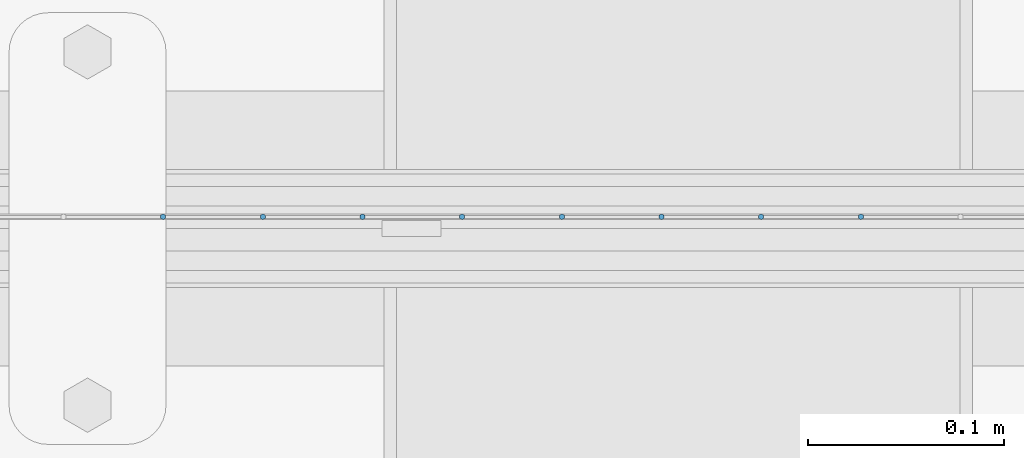
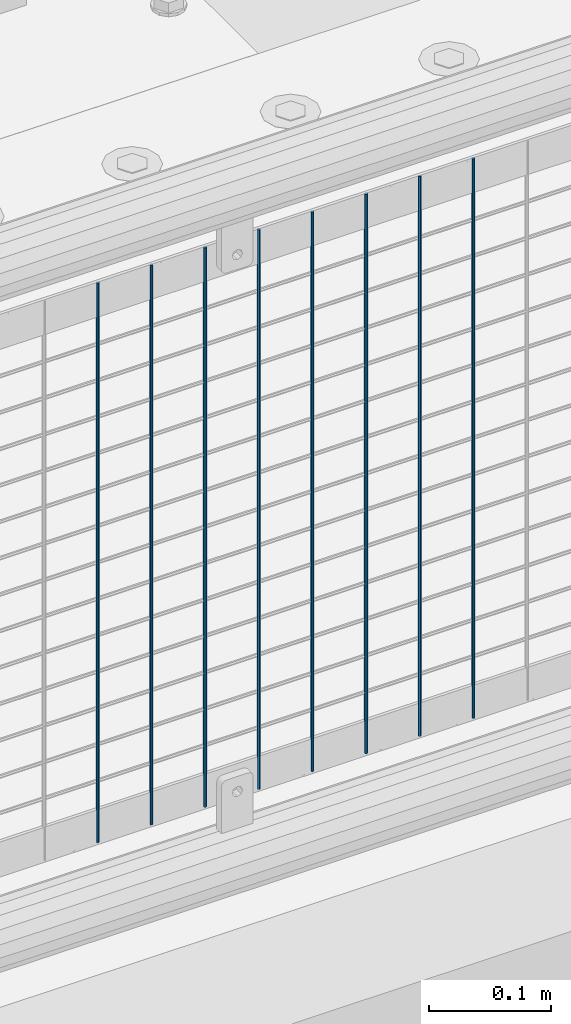
# One storey, part 100 of 242: 8 columns.
"""IFC2X3 building model written with IfcOpenShell, lengths in millimetres."""

from ifc_helpers import new_model, si_unit, frame, origin_with_axes, place, context, subcontext, project, spatial, faceted_brep, material, type_object, element, save


model = new_model("IFC2X3")

# Units and contexts
model_context = context("Model", 3, precision=1e-05, world=origin_with_axes())
body_context = subcontext(model_context, "Body", "Model", "MODEL_VIEW")
ifc_project = project(units=[si_unit("LENGTHUNIT", "METRE", prefix="MILLI"), si_unit("AREAUNIT", "SQUARE_METRE"), si_unit("VOLUMEUNIT", "CUBIC_METRE"), si_unit("MASSUNIT", "GRAM", prefix="KILO"), si_unit("TIMEUNIT", "SECOND"), si_unit("PLANEANGLEUNIT", "RADIAN"), si_unit("SOLIDANGLEUNIT", "STERADIAN"), si_unit("THERMODYNAMICTEMPERATUREUNIT", "DEGREE_CELSIUS"), si_unit("LUMINOUSINTENSITYUNIT", "LUMEN")], contexts=[model_context])

# Site, building, storey
site_placement = place(None, origin_with_axes())
site = spatial("IfcSite", under=ifc_project, at=site_placement, CompositionType="ELEMENT")
building_placement = place(site_placement, origin_with_axes())
building = spatial("IfcBuilding", under=site, at=building_placement, Name="Standard", CompositionType="ELEMENT")
storey_placement = place(building_placement, origin_with_axes())
storey = spatial("IfcBuildingStorey", under=building, at=storey_placement, Name="Undefined", CompositionType="ELEMENT", Elevation=0.0)

# Columns
ifc_material = material(Name="Misc_Undefined")
column_type = type_object("IfcColumnType", Name="D3", PredefinedType="NOTDEFINED")
for number, where, z_axis, x_axis in (
    (1, (-26086.933, -19329.5, 353.02), (-1.0, 0.0, 0.0), (0.0, 0.0, 1.0)),
    (2, (-26137.726, -19329.5, 353.02), (-1.0, 0.0, 0.0), (0.0, 0.0, 1.0)),
    (3, (-26188.519, -19329.5, 353.02), (-1.0, 0.0, 0.0), (0.0, 0.0, 1.0)),
    (4, (-26239.312, -19329.5, 353.02), (-1.0, 0.0, 0.0), (0.0, 0.0, 1.0)),
    (5, (-26290.105, -19329.5, 353.02), (-1.0, 0.0, 0.0), (0.0, 0.0, 1.0)),
    (6, (-26340.898, -19329.5, 353.02), (-1.0, 0.0, 0.0), (0.0, 0.0, 1.0)),
    (7, (-26391.691, -19329.5, 353.02), (-1.0, 0.0, 0.0), (0.0, 0.0, 1.0)),
    (8, (-26442.484, -19329.5, 353.02), (-1.0, 0.0, 0.0), (0.0, 0.0, 1.0)),
):
    element("IfcColumn", number, at=place(storey_placement, frame(where, z_axis=z_axis, x_axis=x_axis)), inside=storey, type_object=column_type, material=ifc_material, ObjectType="D3", context=body_context, shape_type="Brep", body=[
        faceted_brep([(0.0, -1.50000000000364, 0.0), (-3.63797880709171e-12, -0.750000000003638, -1.29903810567669), (560.0, -0.75, -1.29903810567703), (560.0, -1.5, 0.0), (0.0, 0.749999999996362, -1.29903810567669), (560.0, 0.75, -1.29903810567703), (-3.63797880709171e-12, 1.49999999999636, 0.0), (560.0, 1.5, 0.0), (0.0, 0.749999999996362, 1.29903810567669), (560.0, 0.75, 1.29903810567703), (-3.63797880709171e-12, -0.750000000003638, 1.29903810567669), (560.0, -0.75, 1.29903810567703)], [[[0, 1, 2, 3]], [[1, 4, 5, 2]], [[4, 6, 7, 5]], [[6, 8, 9, 7]], [[8, 10, 11, 9]], [[10, 0, 3, 11]], [[5, 7, 9, 11, 3, 2]], [[10, 8, 6, 4, 1, 0]]]),
    ])

save(model, "model.ifc")
